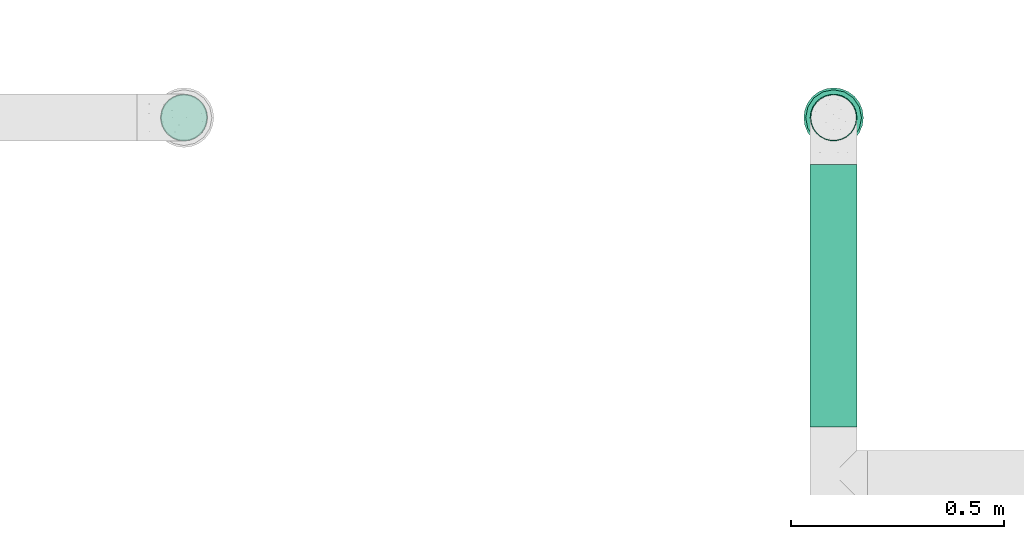
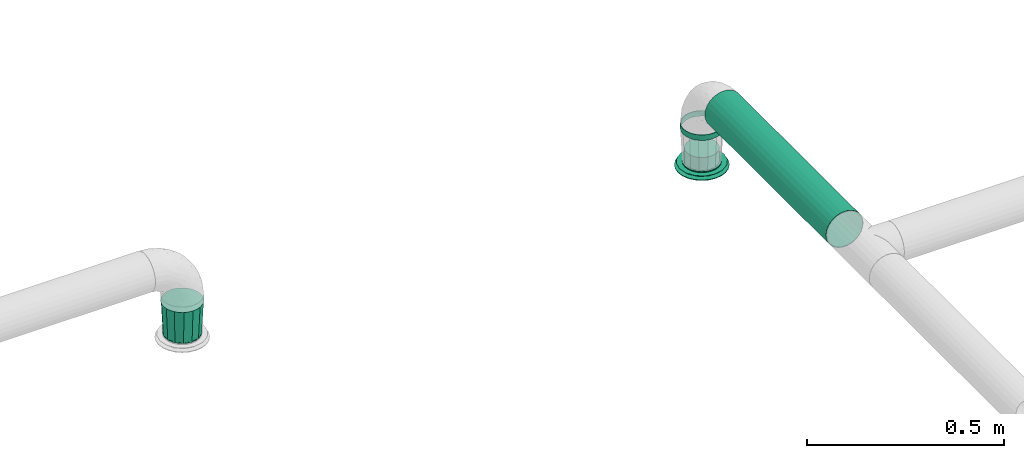
# One storey, part 81 of 123: 2 flow segments, 1 flow fitting, 1 flow terminal.
"""IFC2X3 building model written with IfcOpenShell, lengths in millimetres."""

from ifc_helpers import new_model, entity, si_unit, converted_unit, derived_unit, direction, frame, origin_with_axes, origin_2d_with_axis, place, context, subcontext, project, spatial, hollow_circle, extrude, open_shell, surface_model, source, transform, mapped, material, layer, layer_set, layer_usage, type_object, element, save


model = new_model("IFC2X3")

# Units and contexts
model_context = context("Model", 3, precision=1e-05, world=origin_with_axes(), true_north=direction((0.0, 1.0)))
body_context = subcontext(model_context, "Body", "Model", "MODEL_VIEW")
ifc_project = project(units=[si_unit("AREAUNIT", "SQUARE_METRE"), si_unit("VOLUMEUNIT", "CUBIC_METRE", prefix="DECI"), si_unit("TIMEUNIT", "SECOND"), si_unit("THERMODYNAMICTEMPERATUREUNIT", "DEGREE_CELSIUS"), si_unit("PRESSUREUNIT", "PASCAL"), si_unit("MASSUNIT", "GRAM", prefix="KILO"), si_unit("LENGTHUNIT", "METRE", prefix="MILLI"), si_unit("POWERUNIT", "WATT"), si_unit("ELECTRICCURRENTUNIT", "AMPERE"), si_unit("ELECTRICVOLTAGEUNIT", "VOLT"), derived_unit("VOLUMETRICFLOWRATEUNIT", [(si_unit("VOLUMEUNIT", "CUBIC_METRE", prefix="DECI"), 1), (si_unit("TIMEUNIT", "SECOND"), -1)]), derived_unit("LINEARVELOCITYUNIT", [(si_unit("LENGTHUNIT", "METRE"), 1), (si_unit("TIMEUNIT", "SECOND"), -1)]), derived_unit("MASSDENSITYUNIT", [(si_unit("MASSUNIT", "GRAM", prefix="KILO"), 1), (si_unit("VOLUMEUNIT", "CUBIC_METRE"), -1)]), converted_unit("PLANEANGLEUNIT", "DEGREE", entity("IfcRatioMeasure", 0.01745), si_unit("PLANEANGLEUNIT", "RADIAN"), dimensions=[0, 0, 0, 0, 0, 0, 0])], contexts=[model_context])

# Site, building, storey
site_placement = place(None, origin_with_axes())
site = spatial("IfcSite", under=ifc_project, at=site_placement, CompositionType="ELEMENT")
building_placement = place(site_placement, origin_with_axes())
building = spatial("IfcBuilding", under=site, at=building_placement, Name="mc-building", CompositionType="ELEMENT")
storey_placement = place(building_placement, origin_with_axes())
storey = spatial("IfcBuildingStorey", under=building, at=storey_placement, Name="1. Korrus", CompositionType="ELEMENT", Elevation=0.0)

# Flow terminal
air_terminal_type = type_object("IfcAirTerminalType", Name="100", PredefinedType="NOTDEFINED")
shared_shape_1 = source(origin_with_axes(), body_context, "Body", "SurfaceModel", [
    surface_model("IfcShellBasedSurfaceModel", [(11.2, 18.11733, -67.61481), (11.2, -18.11733, -67.61481), (11.2, 0.0, -70.0), (11.2, 67.61481, -18.11733), (11.2, 35.0, -60.62178), (11.2, 49.49747, -49.49747), (11.2, 60.62178, -35.0), (11.2, -67.61481, 18.11733), (11.2, -49.49747, -49.49747), (11.2, -67.61481, -18.11733), (11.2, -35.0, -60.62178), (11.2, -60.62178, -35.0), (11.2, -70.0, 0.0), (11.2, 18.11733, 67.61481), (11.2, 70.0, 0.0), (11.2, 67.61481, 18.11733), (11.2, 49.49747, 49.49747), (11.2, 60.62178, 35.0), (11.2, 35.0, 60.62178), (11.2, -49.49747, 49.49747), (11.2, -60.62178, 35.0), (11.2, -35.0, 60.62178), (11.2, -18.11733, 67.61481), (11.2, 0.0, 70.0), (9.2, 18.11733, 67.61481), (9.2, -67.61481, 18.11733), (9.2, 0.0, 70.0), (9.2, 49.49747, 49.49747), (9.2, 35.0, 60.62178), (9.2, 60.62178, 35.0), (9.2, 67.61481, 18.11733), (9.2, -35.0, 60.62178), (9.2, -49.49747, 49.49747), (9.2, -18.11733, 67.61481), (9.2, -60.62178, 35.0), (9.2, -67.61481, -18.11733), (9.2, -70.0, 0.0), (9.2, 67.61481, -18.11733), (9.2, 18.11733, -67.61481), (9.2, 49.49747, -49.49747), (9.2, 60.62178, -35.0), (9.2, 35.0, -60.62178), (9.2, -18.11733, -67.61481), (9.2, -49.49747, -49.49747), (9.2, -60.62178, -35.0), (9.2, -35.0, -60.62178), (9.2, 0.0, -70.0), (9.2, 70.0, 0.0), (9.2, 32.75, 0.0), (9.2, -16.375, 28.36233), (9.2, -28.36233, 16.375), (9.2, 16.375, 28.36233), (9.2, 0.0, 32.75), (9.2, 28.36233, 16.375), (9.2, -32.75, 0.0), (9.2, -16.375, -28.36233), (9.2, 16.375, -28.36233), (9.2, 0.0, -32.75), (9.2, 28.36233, -16.375), (9.2, -28.36233, -16.375), (6.2, -21.19625, -15.39997), (6.2, -21.19625, 15.39997), (6.2, 8.09625, 24.91768), (6.2, -8.09625, 24.91768), (6.2, -26.2, 0.0), (6.2, 21.19625, 15.39997), (6.2, -8.09625, -24.91768), (6.2, 21.19625, -15.39997), (6.2, 8.09625, -24.91768), (6.2, 26.2, 0.0), (9.2, 31.06579, -6.28555), (6.2, 23.69812, -7.69999), (6.2, -14.64625, -20.15883), (9.2, -22.36867, -22.36867), (6.2, -23.69812, -7.69999), (9.2, -31.06579, -6.28555), (6.2, 14.64625, -20.15883), (9.2, 8.1875, -30.55617), (6.2, 0.0, -24.91768), (9.2, 22.36867, -22.36867), (9.2, -8.1875, -30.55617), (9.2, -31.06579, 6.28555), (6.2, -23.69812, 7.69999), (6.2, 14.64625, 20.15883), (9.2, 22.36867, 22.36867), (6.2, 23.69812, 7.69999), (9.2, 31.06579, 6.28555), (6.2, -14.64625, 20.15883), (9.2, -8.1875, 30.55617), (6.2, 0.0, 24.91768), (9.2, -22.36867, 22.36867), (9.2, 8.1875, 30.55617), (6.2, -13.11761, 57.472), (6.2, -36.75472, 46.08897), (6.2, -53.11211, 25.57744), (6.2, 36.75472, 46.08897), (6.2, -58.95, 0.0), (6.2, 13.11761, 57.472), (6.2, 53.11211, 25.57744), (6.2, -53.11211, -25.57744), (6.2, -36.75472, -46.08897), (6.2, -13.11761, -57.472), (6.2, 58.95, 0.0), (6.2, 53.11211, -25.57744), (6.2, 13.11761, -57.472), (6.2, 36.75472, -46.08897), (0.0, -60.51411, 25.06576), (0.0, 0.0, 65.5), (0.0, 25.06576, 60.51411), (0.0, 46.3155, 46.3155), (0.0, 60.51411, 25.06576), (0.0, -46.3155, 46.3155), (0.0, -25.06576, 60.51411), (0.0, 0.0, -65.5), (0.0, -65.5, 0.0), (0.0, 65.5, 0.0), (0.0, 60.51411, -25.06576), (0.0, 46.3155, -46.3155), (0.0, 25.06576, -60.51411), (0.0, -46.3155, -46.3155), (0.0, -60.51411, -25.06576), (0.0, -25.06576, -60.51411), (6.2, 56.03105, -12.78872), (0.0, 53.4148, -35.69063), (0.0, 35.69063, -53.4148), (6.2, 24.93616, -51.78048), (0.0, -12.53288, -63.00706), (6.2, 0.0, -57.472), (0.0, -35.69063, -53.4148), (0.0, 63.00706, -12.53288), (6.2, 44.93342, -35.83321), (6.2, -24.93616, -51.78048), (6.2, -44.93342, -35.83321), (0.0, -53.4148, -35.69063), (0.0, 12.53288, -63.00706), (6.2, -56.03105, -12.78872), (0.0, -63.00706, -12.53288), (6.2, -56.03105, 12.78872), (0.0, -53.4148, 35.69063), (0.0, -35.69063, 53.4148), (6.2, -24.93616, 51.78048), (0.0, 12.53288, 63.00706), (6.2, 0.0, 57.472), (0.0, 35.69063, 53.4148), (0.0, -63.00706, 12.53288), (6.2, -44.93342, 35.83321), (6.2, 24.93616, 51.78048), (6.2, 44.93342, 35.83321), (0.0, 53.4148, 35.69063), (0.0, -12.53288, 63.00706), (6.2, 56.03105, 12.78872), (0.0, 63.00706, 12.53288), (-3.1, 12.94095, 48.29629), (-3.1, -35.35534, 35.35534), (-3.1, 0.0, 50.0), (-3.1, 35.35534, 35.35534), (-3.1, 25.0, 43.30127), (-3.1, -43.30127, 25.0), (-3.1, 43.30127, 25.0), (-3.1, -48.29629, -12.94095), (-3.1, -12.94095, 48.29629), (-3.1, -25.0, 43.30127), (-3.1, -50.0, 0.0), (-3.1, -48.29629, 12.94095), (-3.1, 48.29629, 12.94095), (-3.1, 12.94095, -48.29629), (-3.1, 50.0, 0.0), (-3.1, 48.29629, -12.94095), (-3.1, 35.35534, -35.35534), (-3.1, 43.30127, -25.0), (-3.1, 25.0, -43.30127), (-3.1, 0.0, -50.0), (-3.1, -35.35534, -35.35534), (-3.1, -43.30127, -25.0), (-3.1, -25.0, -43.30127), (-3.1, -12.94095, -48.29629), (0.0, 25.0, -43.30127), (0.0, 0.0, -50.0), (0.0, 12.94095, -48.29629), (0.0, 48.29629, -12.94095), (0.0, 35.35534, -35.35534), (0.0, -25.0, -43.30127), (0.0, 43.30127, -25.0), (0.0, -50.0, 0.0), (0.0, -12.94095, -48.29629), (0.0, -35.35534, -35.35534), (0.0, -48.29629, -12.94095), (0.0, -43.30127, -25.0), (0.0, 50.0, 0.0), (0.0, 43.30127, 25.0), (0.0, 12.94095, 48.29629), (0.0, 35.35534, 35.35534), (0.0, 25.0, 43.30127), (0.0, 0.0, 50.0), (0.0, -35.35534, 35.35534), (0.0, -43.30127, 25.0), (0.0, -48.29629, 12.94095), (0.0, -12.94095, 48.29629), (0.0, -25.0, 43.30127), (0.0, 48.29629, 12.94095), (-43.1, 0.0, 45.0), (-43.1, 11.64686, 43.46666), (-43.1, 22.5, 38.97115), (-43.1, -11.64686, 43.46666), (-43.1, 38.97115, 22.5), (-43.1, 43.46666, 11.64686), (-43.1, 31.81981, 31.81981), (-43.1, -22.5, 38.97115), (-43.1, -43.46666, 11.64686), (-43.1, -31.81981, 31.81981), (-43.1, -38.97115, 22.5), (-43.1, -45.0, 0.0), (-43.1, -43.46666, -11.64686), (-43.1, 45.0, 0.0), (-43.1, 43.46666, -11.64686), (-43.1, 38.97115, -22.5), (-43.1, 31.81981, -31.81981), (-43.1, 22.5, -38.97115), (-43.1, 11.64686, -43.46666), (-43.1, -31.81981, -31.81981), (-43.1, -38.97115, -22.5), (-43.1, -22.5, -38.97115), (-43.1, 0.0, -45.0), (-43.1, -11.64686, -43.46666), (-3.1, 22.5, -38.97115), (-3.1, 0.0, -45.0), (-3.1, 11.64686, -43.46666), (-3.1, 31.81981, -31.81981), (-3.1, -22.5, -38.97115), (-3.1, 38.97115, -22.5), (-3.1, 43.46666, -11.64686), (-3.1, 45.0, 0.0), (-3.1, -45.0, 0.0), (-3.1, -11.64686, -43.46666), (-3.1, -31.81981, -31.81981), (-3.1, -43.46666, -11.64686), (-3.1, -38.97115, -22.5), (-3.1, 0.0, 45.0), (-3.1, 43.46666, 11.64686), (-3.1, 38.97115, 22.5), (-3.1, 22.5, 38.97115), (-3.1, 31.81981, 31.81981), (-3.1, 11.64686, 43.46666), (-3.1, -11.64686, 43.46666), (-3.1, -43.46666, 11.64686), (-3.1, -31.81981, 31.81981), (-3.1, -38.97115, 22.5), (-3.1, -22.5, 38.97115)], [open_shell([[[0, 1, 2]], [[3, 0, 4]], [[5, 6, 3]], [[5, 3, 4]], [[7, 1, 0]], [[8, 7, 9]], [[10, 7, 8]], [[8, 9, 11]], [[12, 9, 7]], [[1, 7, 10]], [[7, 0, 3]], [[13, 14, 15]], [[16, 15, 17]], [[16, 18, 13]], [[16, 13, 15]], [[14, 13, 7]], [[7, 19, 20]], [[19, 7, 21]], [[7, 22, 21]], [[22, 7, 23]], [[7, 13, 23]], [[14, 7, 3]], [[24, 25, 26]], [[27, 24, 28]], [[27, 29, 30]], [[27, 30, 24]], [[25, 24, 30]], [[31, 25, 32]], [[25, 31, 33]], [[32, 25, 34]], [[33, 26, 25]], [[25, 35, 36]], [[25, 30, 37]], [[25, 37, 38]], [[39, 37, 40]], [[39, 41, 38]], [[39, 38, 37]], [[38, 42, 25]], [[35, 43, 44]], [[35, 25, 43]], [[45, 43, 25]], [[42, 45, 25]], [[38, 46, 42]], [[37, 30, 47]], [[35, 9, 36]], [[44, 11, 35]], [[10, 43, 45]], [[44, 43, 8]], [[1, 45, 42]], [[35, 11, 9]], [[9, 12, 36]], [[1, 10, 45]], [[8, 43, 10]], [[8, 11, 44]], [[2, 1, 42]], [[42, 46, 2]], [[38, 0, 46]], [[41, 4, 38]], [[6, 39, 40]], [[41, 39, 5]], [[3, 40, 37]], [[41, 5, 4]], [[4, 0, 38]], [[14, 3, 37]], [[6, 40, 3]], [[6, 5, 39]], [[47, 14, 37]], [[46, 0, 2]], [[30, 15, 47]], [[29, 17, 30]], [[18, 27, 28]], [[29, 27, 16]], [[13, 28, 24]], [[30, 17, 15]], [[15, 14, 47]], [[13, 18, 28]], [[16, 27, 18]], [[16, 17, 29]], [[23, 13, 24]], [[24, 26, 23]], [[33, 22, 26]], [[31, 21, 33]], [[20, 32, 34]], [[31, 32, 19]], [[7, 34, 25]], [[31, 19, 21]], [[21, 22, 33]], [[12, 7, 25]], [[20, 34, 7]], [[20, 19, 32]], [[36, 12, 25]], [[26, 22, 23]], [[48, 49, 50]], [[48, 51, 49]], [[49, 51, 52]], [[53, 51, 48]], [[48, 50, 54]], [[54, 55, 48]], [[56, 55, 57]], [[55, 58, 48]], [[58, 55, 56]], [[55, 54, 59]], [[60, 61, 62]], [[62, 61, 63]], [[64, 61, 60]], [[62, 65, 66]], [[67, 68, 65]], [[66, 60, 62]], [[65, 68, 66]], [[69, 67, 65]], [[69, 48, 70]], [[58, 71, 70]], [[72, 73, 60]], [[59, 74, 60]], [[75, 64, 74]], [[56, 68, 76]], [[72, 66, 55]], [[73, 72, 55]], [[68, 77, 78]], [[64, 75, 54]], [[59, 75, 74]], [[70, 71, 69]], [[67, 79, 76]], [[80, 55, 66]], [[68, 56, 77]], [[56, 76, 79]], [[79, 67, 58]], [[71, 58, 67]], [[80, 78, 57]], [[77, 57, 78]], [[66, 78, 80]], [[59, 60, 73]], [[64, 54, 81]], [[50, 82, 81]], [[83, 84, 65]], [[53, 85, 65]], [[86, 69, 85]], [[49, 63, 87]], [[83, 62, 51]], [[84, 83, 51]], [[63, 88, 89]], [[69, 86, 48]], [[53, 86, 85]], [[81, 82, 64]], [[61, 90, 87]], [[91, 51, 62]], [[63, 49, 88]], [[49, 87, 90]], [[90, 61, 50]], [[82, 50, 61]], [[91, 89, 52]], [[88, 52, 89]], [[62, 89, 91]], [[53, 65, 84]], [[92, 93, 94]], [[95, 94, 96]], [[97, 92, 95]], [[95, 92, 94]], [[96, 98, 95]], [[96, 99, 98]], [[99, 100, 101]], [[101, 102, 98]], [[102, 101, 103]], [[104, 105, 103]], [[101, 104, 103]], [[101, 98, 99]], [[106, 107, 108]], [[109, 110, 108]], [[106, 108, 110]], [[111, 112, 106]], [[106, 112, 107]], [[106, 113, 114]], [[106, 110, 113]], [[115, 116, 117]], [[117, 113, 110]], [[113, 117, 118]], [[114, 119, 120]], [[121, 119, 114]], [[121, 114, 113]], [[115, 117, 110]], [[103, 116, 122]], [[123, 116, 103]], [[124, 125, 118]], [[101, 126, 127]], [[100, 119, 128]], [[102, 122, 129]], [[103, 130, 123]], [[102, 129, 115]], [[113, 127, 126]], [[125, 124, 105]], [[130, 105, 117]], [[118, 125, 104]], [[124, 117, 105]], [[131, 100, 128]], [[119, 100, 132]], [[133, 99, 120]], [[134, 118, 104]], [[122, 116, 129]], [[127, 134, 104]], [[131, 121, 101]], [[99, 133, 132]], [[128, 121, 131]], [[130, 117, 123]], [[101, 121, 126]], [[99, 135, 120]], [[96, 136, 135]], [[136, 120, 135]], [[134, 127, 113]], [[133, 119, 132]], [[136, 96, 114]], [[94, 106, 137]], [[138, 106, 94]], [[139, 140, 112]], [[97, 141, 142]], [[95, 109, 143]], [[96, 137, 144]], [[94, 145, 138]], [[96, 144, 114]], [[107, 142, 141]], [[140, 139, 93]], [[145, 93, 111]], [[112, 140, 92]], [[139, 111, 93]], [[146, 95, 143]], [[109, 95, 147]], [[148, 98, 110]], [[149, 112, 92]], [[137, 106, 144]], [[142, 149, 92]], [[146, 108, 97]], [[98, 148, 147]], [[143, 108, 146]], [[145, 111, 138]], [[97, 108, 141]], [[98, 150, 110]], [[102, 151, 150]], [[151, 110, 150]], [[149, 142, 107]], [[148, 109, 147]], [[151, 102, 115]], [[152, 153, 154]], [[155, 152, 156]], [[157, 152, 158]], [[158, 152, 155]], [[158, 159, 157]], [[160, 153, 161]], [[160, 154, 153]], [[157, 162, 163]], [[153, 152, 157]], [[157, 159, 162]], [[158, 164, 159]], [[165, 166, 167]], [[168, 167, 169]], [[170, 165, 167]], [[170, 167, 168]], [[166, 165, 171]], [[159, 172, 173]], [[172, 159, 174]], [[174, 171, 175]], [[159, 164, 174]], [[166, 171, 174]], [[174, 164, 166]], [[176, 177, 178]], [[179, 176, 180]], [[176, 179, 181]], [[179, 180, 182]], [[179, 183, 181]], [[177, 181, 184]], [[177, 176, 181]], [[185, 186, 187]], [[186, 185, 181]], [[181, 183, 186]], [[183, 179, 188]], [[183, 188, 189]], [[190, 189, 191]], [[189, 190, 183]], [[190, 191, 192]], [[193, 194, 190]], [[183, 195, 196]], [[183, 190, 195]], [[194, 197, 198]], [[194, 195, 190]], [[197, 194, 193]], [[189, 188, 199]], [[164, 199, 166]], [[158, 189, 164]], [[192, 155, 156]], [[158, 155, 191]], [[190, 156, 152]], [[164, 189, 199]], [[199, 188, 166]], [[190, 192, 156]], [[191, 155, 192]], [[191, 189, 158]], [[193, 190, 152]], [[152, 154, 193]], [[160, 197, 154]], [[161, 198, 160]], [[195, 153, 157]], [[161, 153, 194]], [[196, 157, 163]], [[161, 194, 198]], [[198, 197, 160]], [[183, 196, 163]], [[195, 157, 196]], [[195, 194, 153]], [[162, 183, 163]], [[154, 197, 193]], [[159, 186, 162]], [[173, 187, 159]], [[181, 172, 174]], [[173, 172, 185]], [[184, 174, 175]], [[159, 187, 186]], [[186, 183, 162]], [[184, 181, 174]], [[185, 172, 181]], [[185, 187, 173]], [[177, 184, 175]], [[175, 171, 177]], [[165, 178, 171]], [[170, 176, 165]], [[182, 168, 169]], [[170, 168, 180]], [[179, 169, 167]], [[170, 180, 176]], [[176, 178, 165]], [[188, 179, 167]], [[182, 169, 179]], [[182, 180, 168]], [[166, 188, 167]], [[171, 178, 177]], [[200, 201, 202]], [[203, 200, 202]], [[204, 205, 202]], [[204, 202, 206]], [[203, 202, 205]], [[207, 208, 209]], [[207, 203, 205]], [[209, 208, 210]], [[211, 208, 212]], [[208, 207, 212]], [[207, 205, 212]], [[213, 214, 215]], [[205, 215, 212]], [[212, 216, 217]], [[216, 212, 215]], [[218, 219, 217]], [[212, 219, 220]], [[212, 217, 219]], [[221, 222, 223]], [[222, 221, 219]], [[218, 222, 219]], [[215, 205, 213]], [[224, 225, 226]], [[227, 228, 224]], [[229, 230, 231]], [[228, 227, 229]], [[229, 232, 228]], [[225, 228, 233]], [[225, 224, 228]], [[234, 235, 236]], [[235, 234, 228]], [[228, 232, 235]], [[232, 229, 231]], [[237, 238, 239]], [[240, 239, 241]], [[240, 242, 237]], [[240, 237, 239]], [[238, 237, 243]], [[244, 245, 246]], [[247, 244, 232]], [[244, 247, 245]], [[232, 238, 247]], [[238, 243, 247]], [[238, 232, 231]], [[205, 238, 213]], [[204, 239, 205]], [[240, 206, 202]], [[204, 206, 241]], [[242, 202, 201]], [[205, 239, 238]], [[238, 231, 213]], [[240, 202, 242]], [[241, 206, 240]], [[241, 239, 204]], [[201, 237, 242]], [[201, 200, 237]], [[243, 203, 207]], [[209, 247, 207]], [[246, 210, 208]], [[209, 210, 245]], [[244, 208, 211]], [[203, 243, 200]], [[207, 247, 243]], [[200, 243, 237]], [[209, 245, 247]], [[210, 246, 245]], [[244, 246, 208]], [[211, 232, 244]], [[212, 235, 211]], [[220, 236, 212]], [[228, 219, 221]], [[220, 219, 234]], [[233, 221, 223]], [[212, 236, 235]], [[235, 232, 211]], [[233, 228, 221]], [[234, 219, 228]], [[234, 236, 220]], [[225, 233, 223]], [[223, 222, 225]], [[226, 218, 217]], [[216, 224, 217]], [[229, 215, 214]], [[216, 215, 227]], [[230, 214, 213]], [[218, 226, 222]], [[217, 224, 226]], [[222, 226, 225]], [[216, 227, 224]], [[215, 229, 227]], [[230, 229, 214]], [[213, 231, 230]]])]),
])
flow_terminal_placement = place(storey_placement, frame((29788.00747, 3871.31763, 2200.0), z_axis=(0.0, -1.0, 0.0), x_axis=(0.0, 0.0, -1.0)))
element("IfcFlowTerminal", 1, at=flow_terminal_placement, inside=storey, type_object=air_terminal_type, Name="100", context=body_context, shape_type="MappedRepresentation", body=[
    mapped(shared_shape_1, transform((0.0, 0.0, 0.0), scale=1.0)),
])

# Flow fitting
duct_fitting_type = type_object("IfcDuctFittingType", PredefinedType="TRANSITION")
shared_shape_2 = source(origin_with_axes(), body_context, "Body", "SurfaceModel", [
    surface_model("IfcShellBasedSurfaceModel", [(100.0, -55.0, 0.0), (100.0, -12.23865, 53.62104), (100.0, -34.29194, 43.00073), (100.0, 49.55329, 23.86361), (100.0, 34.29194, 43.00073), (100.0, 49.55329, -23.86361), (0.0, -45.04844, -21.69419), (0.0, -50.0, 0.0), (0.0, -45.04844, 21.69419), (0.0, 31.17449, 39.09157), (0.0, 45.04844, 21.69419), (0.0, 50.0, 0.0), (98.0, 47.63139, 27.5), (98.0, 0.0, 55.0), (98.0, 38.89087, 38.89087), (98.0, -38.89087, 38.89087), (98.0, -47.63139, 27.5), (100.0, 12.23865, 53.62104), (100.0, -49.55329, 23.86361), (100.0, 55.0, 0.0), (100.0, 12.23865, -53.62104), (100.0, 34.29194, -43.00073), (100.0, -49.55329, -23.86361), (100.0, -34.29194, -43.00073), (100.0, -12.23865, -53.62104), (0.0, -31.17449, 39.09157), (0.0, -11.12605, 48.7464), (0.0, 11.12605, 48.7464), (0.0, -31.17449, -39.09157), (0.0, 11.12605, -48.7464), (0.0, -11.12605, -48.7464), (0.0, 45.04844, -21.69419), (0.0, 31.17449, -39.09157), (0.0, 47.52422, -10.84709), (0.0, 38.11147, -30.39288), (100.0, 41.92261, -33.43217), (100.0, -41.92261, -33.43217), (0.0, -38.11147, -30.39288), (100.0, 23.2653, -48.31088), (0.0, 21.15027, -43.91899), (100.0, 52.32388, -11.72483), (0.0, 0.0, -48.7464), (100.0, 0.0, -53.62104), (0.0, -21.15027, -43.91899), (100.0, -23.2653, -48.31088), (0.0, -47.52422, -10.84709), (100.0, -52.32388, -11.72483), (0.0, -47.52422, 10.84709), (0.0, -38.11147, 30.39288), (100.0, -41.92261, 33.43217), (100.0, 41.92261, 33.43217), (0.0, 38.11147, 30.39288), (100.0, -23.2653, 48.31088), (0.0, -21.15027, 43.91899), (100.0, -52.32388, 11.72483), (0.0, 0.0, 48.7464), (100.0, 0.0, 53.62104), (0.0, 21.15027, 43.91899), (100.0, 23.2653, 48.31088), (0.0, 47.52422, 10.84709), (100.0, 52.32388, 11.72483), (100.0, -14.23505, -53.12592), (100.0, 0.0, -55.0), (100.0, -27.5, -47.63139), (100.0, 27.5, -47.63139), (100.0, -38.89087, -38.89087), (100.0, -53.12592, -14.23505), (100.0, -47.63139, -27.5), (100.0, -47.63139, 27.5), (100.0, 14.23505, -53.12592), (100.0, 38.89087, -38.89087), (100.0, 47.63139, -27.5), (100.0, 47.63139, 27.5), (100.0, 53.12592, -14.23505), (100.0, -53.12592, 14.23505), (100.0, -38.89087, 38.89087), (100.0, -27.5, 47.63139), (100.0, 0.0, 55.0), (100.0, -14.23505, 53.12592), (100.0, 53.12592, 14.23505), (100.0, 38.89087, 38.89087), (100.0, 27.5, 47.63139), (100.0, 14.23505, 53.12592), (98.0, -27.5, 47.63139), (98.0, -14.23505, 53.12592), (98.0, -53.12592, -14.23505), (98.0, 14.23505, 53.12592), (98.0, 27.5, 47.63139), (98.0, 53.12592, 14.23505), (98.0, 55.0, 0.0), (98.0, -47.63139, -27.5), (98.0, -53.12592, 14.23505), (98.0, 27.5, -47.63139), (98.0, -27.5, -47.63139), (98.0, -38.89087, -38.89087), (98.0, 0.0, -55.0), (98.0, -14.23505, -53.12592), (98.0, 38.89087, -38.89087), (98.0, 47.63139, -27.5), (98.0, 53.12592, -14.23505), (98.0, 14.23505, -53.12592), (98.0, -55.0, 0.0), (0.0, 0.0, 50.0), (0.0, 35.35534, 35.35534), (0.0, -12.94095, 48.29629), (0.0, -25.0, 43.30127), (0.0, -35.35534, 35.35534), (0.0, -48.29629, 12.94095), (0.0, -43.30127, 25.0), (0.0, 25.0, 43.30127), (0.0, 12.94095, 48.29629), (0.0, 43.30127, 25.0), (0.0, 48.29629, 12.94095), (0.0, 25.0, -43.30127), (0.0, 48.29629, -12.94095), (0.0, -48.29629, -12.94095), (0.0, -43.30127, -25.0), (0.0, -12.94095, -48.29629), (0.0, -25.0, -43.30127), (0.0, -35.35534, -35.35534), (0.0, 43.30127, -25.0), (0.0, 35.35534, -35.35534), (0.0, 12.94095, -48.29629), (0.0, 0.0, -50.0), (2.0, -35.35534, -35.35534), (2.0, -25.0, -43.30127), (2.0, -12.94095, -48.29629), (2.0, -43.30127, -25.0), (2.0, 0.0, -50.0), (2.0, -48.29629, -12.94095), (2.0, -50.0, 0.0), (2.0, 12.94095, -48.29629), (2.0, 25.0, -43.30127), (2.0, 43.30127, -25.0), (2.0, 48.29629, -12.94095), (2.0, 35.35534, -35.35534), (2.0, -48.29629, 12.94095), (2.0, -35.35534, 35.35534), (2.0, -43.30127, 25.0), (2.0, 35.35534, 35.35534), (2.0, -12.94095, 48.29629), (2.0, -25.0, 43.30127), (2.0, 0.0, 50.0), (2.0, 43.30127, 25.0), (2.0, 48.29629, 12.94095), (2.0, 50.0, 0.0), (2.0, 25.0, 43.30127), (2.0, 12.94095, 48.29629)], [open_shell([[[0, 1, 2]], [[3, 4, 5]], [[6, 7, 8]], [[9, 10, 11]], [[12, 13, 14]], [[15, 13, 16]], [[0, 4, 17]], [[2, 18, 0]], [[1, 0, 17]], [[3, 5, 19]], [[20, 21, 5]], [[22, 20, 5]], [[22, 5, 0]], [[22, 23, 24]], [[22, 24, 20]], [[4, 0, 5]], [[8, 25, 6]], [[6, 25, 26]], [[6, 26, 27]], [[11, 27, 9]], [[28, 6, 29]], [[30, 28, 29]], [[31, 6, 11]], [[31, 32, 29]], [[31, 29, 6]], [[27, 11, 6]], [[31, 33, 5]], [[34, 35, 32]], [[36, 22, 6]], [[36, 37, 23]], [[38, 29, 39]], [[33, 40, 5]], [[33, 11, 40]], [[19, 40, 11]], [[32, 21, 39]], [[32, 35, 21]], [[34, 31, 35]], [[30, 41, 42]], [[28, 43, 44]], [[42, 41, 20]], [[7, 45, 46]], [[38, 39, 21]], [[46, 0, 7]], [[6, 37, 36]], [[38, 20, 29]], [[43, 30, 24]], [[42, 24, 30]], [[28, 23, 37]], [[6, 22, 45]], [[35, 31, 5]], [[44, 43, 24]], [[20, 41, 29]], [[46, 45, 22]], [[44, 23, 28]], [[8, 47, 18]], [[48, 49, 25]], [[50, 3, 10]], [[50, 51, 4]], [[52, 26, 53]], [[47, 54, 18]], [[47, 7, 54]], [[0, 54, 7]], [[25, 2, 53]], [[25, 49, 2]], [[48, 8, 49]], [[27, 55, 56]], [[9, 57, 58]], [[56, 55, 1]], [[11, 59, 60]], [[52, 53, 2]], [[60, 19, 11]], [[10, 51, 50]], [[52, 1, 26]], [[57, 27, 17]], [[56, 17, 27]], [[9, 4, 51]], [[10, 3, 59]], [[49, 8, 18]], [[58, 57, 17]], [[1, 55, 26]], [[60, 59, 3]], [[58, 4, 9]], [[61, 62, 63]], [[63, 64, 65]], [[66, 67, 68]], [[65, 64, 67]], [[67, 64, 68]], [[69, 64, 62]], [[64, 63, 62]], [[70, 71, 64]], [[72, 64, 71]], [[71, 73, 19]], [[74, 0, 66]], [[72, 68, 64]], [[75, 68, 76]], [[77, 78, 76]], [[72, 76, 68]], [[76, 72, 77]], [[79, 72, 19]], [[19, 72, 71]], [[80, 81, 77]], [[77, 72, 80]], [[82, 77, 81]], [[74, 66, 68]], [[83, 84, 13]], [[15, 83, 13]], [[12, 16, 13]], [[16, 12, 85]], [[86, 87, 13]], [[87, 14, 13]], [[88, 89, 12]], [[89, 90, 12]], [[91, 16, 85]], [[90, 85, 12]], [[89, 92, 90]], [[93, 94, 95]], [[95, 94, 90]], [[96, 93, 95]], [[97, 92, 98]], [[98, 89, 99]], [[100, 95, 92]], [[92, 89, 98]], [[90, 92, 95]], [[101, 91, 85]], [[89, 73, 99]], [[99, 71, 98]], [[92, 97, 64]], [[70, 97, 98]], [[100, 92, 69]], [[73, 71, 99]], [[89, 19, 73]], [[92, 64, 69]], [[64, 97, 70]], [[98, 71, 70]], [[100, 69, 62]], [[62, 95, 100]], [[95, 61, 96]], [[96, 63, 93]], [[90, 94, 67]], [[65, 94, 93]], [[85, 90, 66]], [[63, 65, 93]], [[96, 61, 63]], [[85, 66, 0]], [[66, 90, 67]], [[94, 65, 67]], [[85, 0, 101]], [[62, 61, 95]], [[101, 74, 91]], [[91, 68, 16]], [[83, 15, 76]], [[75, 15, 16]], [[84, 83, 78]], [[74, 68, 91]], [[101, 0, 74]], [[83, 76, 78]], [[76, 15, 75]], [[16, 68, 75]], [[84, 78, 77]], [[77, 13, 84]], [[13, 82, 86]], [[86, 81, 87]], [[12, 14, 72]], [[80, 14, 87]], [[88, 12, 79]], [[81, 80, 87]], [[86, 82, 81]], [[88, 79, 19]], [[79, 12, 72]], [[14, 80, 72]], [[88, 19, 89]], [[77, 82, 13]], [[102, 103, 104]], [[105, 104, 106]], [[107, 108, 106]], [[103, 106, 104]], [[106, 103, 107]], [[109, 103, 110]], [[103, 102, 110]], [[111, 112, 103]], [[113, 103, 112]], [[112, 11, 114]], [[107, 103, 113]], [[113, 115, 107]], [[116, 115, 117]], [[117, 118, 119]], [[116, 117, 119]], [[117, 115, 113]], [[120, 121, 114]], [[113, 114, 121]], [[113, 122, 117]], [[113, 112, 114]], [[117, 122, 123]], [[7, 107, 115]], [[124, 125, 126]], [[127, 124, 126]], [[128, 129, 126]], [[127, 126, 129]], [[130, 129, 128]], [[131, 132, 128]], [[132, 130, 128]], [[133, 134, 135]], [[132, 135, 134]], [[132, 134, 130]], [[134, 136, 130]], [[137, 138, 136]], [[137, 136, 139]], [[140, 137, 139]], [[141, 137, 140]], [[142, 140, 139]], [[143, 139, 144]], [[144, 134, 145]], [[146, 147, 139]], [[139, 136, 144]], [[139, 147, 142]], [[136, 134, 144]], [[11, 134, 114]], [[114, 133, 120]], [[113, 121, 132]], [[135, 121, 120]], [[122, 113, 131]], [[134, 133, 114]], [[11, 145, 134]], [[113, 132, 131]], [[132, 121, 135]], [[120, 133, 135]], [[122, 131, 128]], [[128, 123, 122]], [[123, 126, 117]], [[117, 125, 118]], [[116, 119, 127]], [[124, 119, 118]], [[115, 116, 129]], [[125, 124, 118]], [[117, 126, 125]], [[115, 129, 130]], [[129, 116, 127]], [[119, 124, 127]], [[115, 130, 7]], [[128, 126, 123]], [[7, 136, 107]], [[107, 138, 108]], [[105, 106, 141]], [[137, 106, 108]], [[104, 105, 140]], [[136, 138, 107]], [[7, 130, 136]], [[105, 141, 140]], [[141, 106, 137]], [[108, 138, 137]], [[104, 140, 142]], [[142, 102, 104]], [[102, 147, 110]], [[110, 146, 109]], [[111, 103, 143]], [[139, 103, 109]], [[112, 111, 144]], [[146, 139, 109]], [[110, 147, 146]], [[112, 144, 145]], [[144, 111, 143]], [[103, 139, 143]], [[112, 145, 11]], [[142, 147, 102]]])]),
])
flow_fitting_placement = place(storey_placement, frame((28263.38266, 3871.31763, 2203.1), z_axis=(-1.0, 0.0, 0.0), x_axis=(0.0, 0.0, 1.0)))
element("IfcFlowFitting", 2, at=flow_fitting_placement, inside=storey, type_object=duct_fitting_type, context=body_context, shape_type="MappedRepresentation", body=[
    mapped(shared_shape_2, transform((0.0, 0.0, 0.0), scale=1.0)),
])

# Flow segments
ifc_material = material(Name="FZ1")
ifc_layer = layer(ifc_material, 0.0)
ifc_layer_set = layer_set([ifc_layer], Name="FZ1")
ifc_layer_usage = layer_usage(ifc_layer_set, "AXIS1", "POSITIVE", 0.0)
duct_segment_type = type_object("IfcDuctSegmentType", PredefinedType="RIGIDSEGMENT")
shared_shape_3 = source(origin_with_axes(), body_context, "Body", "SweptSolid", [
    extrude(hollow_circle(Radius=55.0, WallThickness=2.0, at=origin_2d_with_axis()), frame((0.0, 0.0, 0.0), z_axis=(1.0, 0.0, 0.0), x_axis=(0.0, 1.0, 0.0)), (0.0, 0.0, 1.0), 16.9),
])
flow_segment_1_placement = place(storey_placement, frame((29788.00747, 3871.31763, 2320.0), z_axis=(0.0, 1.0, 0.0), x_axis=(0.0, 0.0, -1.0)))
element("IfcFlowSegment", 3, at=flow_segment_1_placement, inside=storey, type_object=duct_segment_type, material=ifc_layer_usage, context=body_context, shape_type="MappedRepresentation", body=[
    mapped(shared_shape_3, transform((0.0, 0.0, 0.0), scale=1.0)),
])
shared_shape_4 = source(origin_with_axes(), body_context, "Body", "SweptSolid", [
    extrude(hollow_circle(Radius=55.0, WallThickness=2.0, at=origin_2d_with_axis()), frame((0.0, 0.0, 0.0), z_axis=(1.0, 0.0, 0.0), x_axis=(0.0, 1.0, 0.0)), (0.0, 0.0, 1.0), 615.9),
])
flow_segment_2_placement = place(storey_placement, frame((29788.00747, 3145.40319, 2430.0), z_axis=(0.0, 0.0, 1.0), x_axis=(0.0, 1.0, 0.0)))
element("IfcFlowSegment", 4, at=flow_segment_2_placement, inside=storey, type_object=duct_segment_type, material=ifc_layer_usage, context=body_context, shape_type="MappedRepresentation", body=[
    mapped(shared_shape_4, transform((0.0, 0.0, 0.0), scale=1.0)),
])

save(model, "model.ifc")
